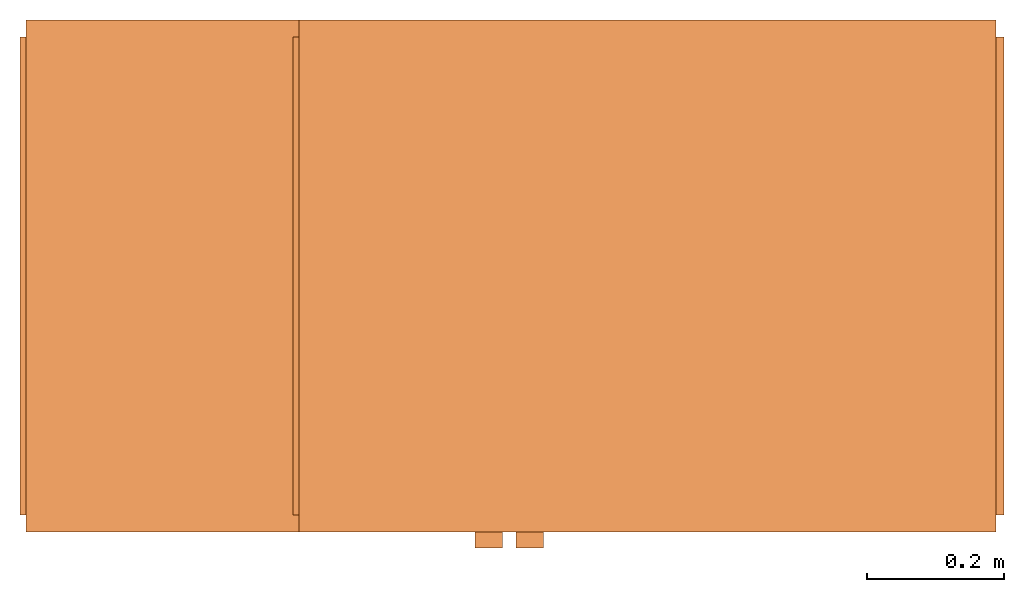
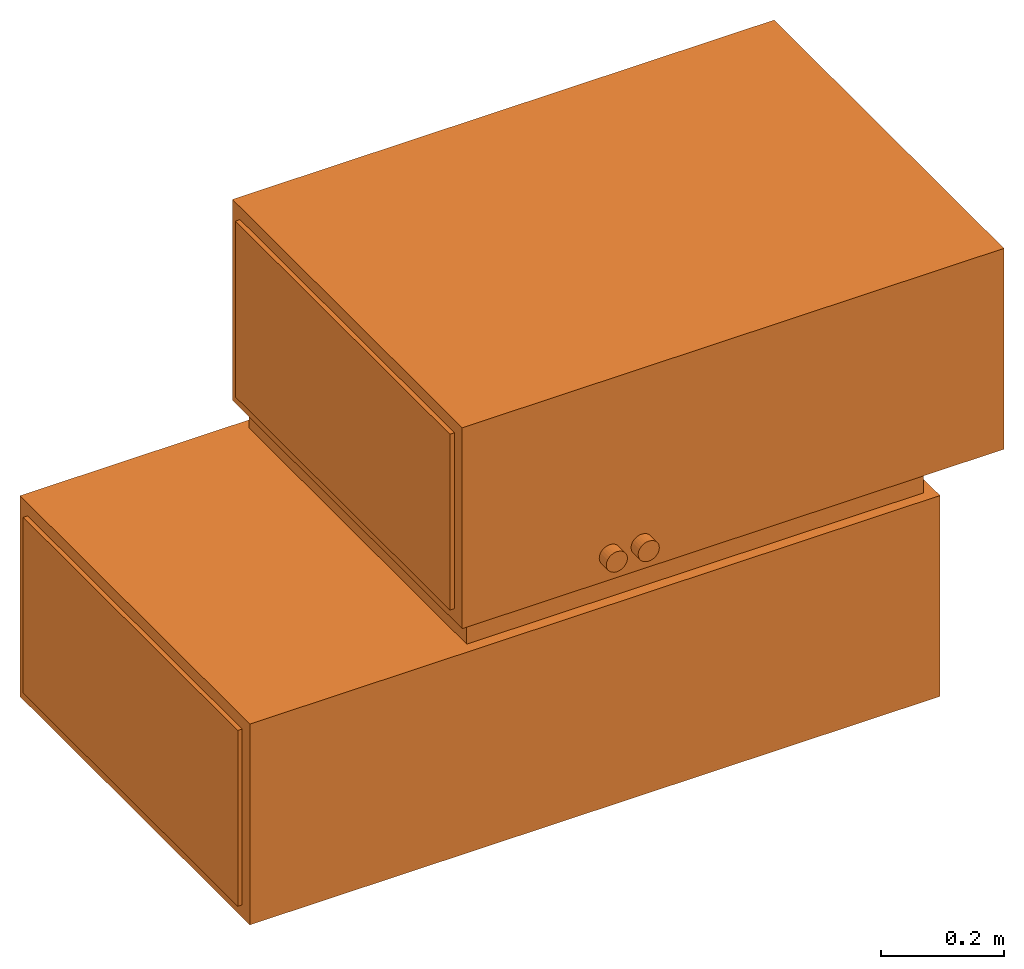
# One storey: 1 proxy.
"""IFC2X3 building model written with IfcOpenShell, lengths in millimetres."""

from ifc_helpers import new_model, entity, si_unit, converted_unit, derived_unit, direction, frame, origin, place, context, subcontext, project, spatial, faceted_brep, source, transform, mapped, type_object, type_shapes, element, save


model = new_model("IFC2X3")

# Units and contexts
model_context = context("Model", 3, precision=0.01, world=origin(), true_north=direction((6.12303176911189e-17, 1.0)))
body_context = subcontext(model_context, "Body", "Model", "MODEL_VIEW")
ifc_project = project(units=[si_unit("LENGTHUNIT", "METRE", prefix="MILLI"), si_unit("AREAUNIT", "SQUARE_METRE"), si_unit("VOLUMEUNIT", "CUBIC_METRE"), converted_unit("PLANEANGLEUNIT", "DEGREE", entity("IfcRatioMeasure", 0.0174532925199433), si_unit("PLANEANGLEUNIT", "RADIAN"), dimensions=[0, 0, 0, 0, 0, 0, 0]), si_unit("MASSUNIT", "GRAM", prefix="KILO"), derived_unit("MASSDENSITYUNIT", [(si_unit("MASSUNIT", "GRAM", prefix="KILO"), 1), (si_unit("LENGTHUNIT", "METRE"), -3)]), si_unit("TIMEUNIT", "SECOND"), si_unit("FREQUENCYUNIT", "HERTZ"), si_unit("THERMODYNAMICTEMPERATUREUNIT", "DEGREE_CELSIUS"), derived_unit("THERMALTRANSMITTANCEUNIT", [(si_unit("MASSUNIT", "GRAM", prefix="KILO"), 1), (si_unit("THERMODYNAMICTEMPERATUREUNIT", "KELVIN"), -1), (si_unit("TIMEUNIT", "SECOND"), -3)]), derived_unit("VOLUMETRICFLOWRATEUNIT", [(si_unit("LENGTHUNIT", "METRE"), 3), (si_unit("TIMEUNIT", "SECOND"), -1)]), si_unit("ELECTRICCURRENTUNIT", "AMPERE"), si_unit("ELECTRICVOLTAGEUNIT", "VOLT"), si_unit("POWERUNIT", "WATT"), si_unit("FORCEUNIT", "NEWTON", prefix="KILO"), si_unit("ILLUMINANCEUNIT", "LUX"), si_unit("LUMINOUSFLUXUNIT", "LUMEN"), si_unit("LUMINOUSINTENSITYUNIT", "CANDELA"), derived_unit("USERDEFINED", [(si_unit("MASSUNIT", "GRAM", prefix="KILO"), -1), (si_unit("LENGTHUNIT", "METRE"), -2), (si_unit("TIMEUNIT", "SECOND"), 3), (si_unit("LUMINOUSFLUXUNIT", "LUMEN"), 1)]), derived_unit("LINEARVELOCITYUNIT", [(si_unit("LENGTHUNIT", "METRE"), 1), (si_unit("TIMEUNIT", "SECOND"), -1)]), si_unit("PRESSUREUNIT", "PASCAL"), derived_unit("USERDEFINED", [(si_unit("LENGTHUNIT", "METRE"), -2), (si_unit("MASSUNIT", "GRAM", prefix="KILO"), 1), (si_unit("TIMEUNIT", "SECOND"), -2)])], contexts=[model_context])

# Site, building, storey
site_placement = place(None, origin())
site = spatial("IfcSite", under=ifc_project, at=site_placement, CompositionType="ELEMENT")
building_placement = place(site_placement, origin())
building = spatial("IfcBuilding", under=site, at=building_placement, CompositionType="ELEMENT")
storey_placement = place(building_placement, frame((0.0, 0.0, 16000.0)))
storey = spatial("IfcBuildingStorey", under=building, at=storey_placement, Name="04 Roof", CompositionType="ELEMENT", Elevation=16000.0)

# Proxy
building_element_proxy_type = type_object("IfcBuildingElementProxyType", PredefinedType="NOTDEFINED")
shared_shape = source(origin(), body_context, "Body", "Brep", [
    faceted_brep([(-163.511826637616, -398.024288, 482.679491924311), (-159.369691013885, -398.024288, 485.857864376269), (-156.191318561927, -398.024288, 490.0), (-154.193310111835, -398.024288, 494.823619097949), (-153.511826637616, -398.024288, 500.0), (-154.193310111834, -398.024288, 505.17638090205), (-156.191318561927, -398.024288, 510.0), (-159.369691013885, -398.024288, 514.142135623731), (-163.511826637616, -398.024288, 517.320508075689), (-168.335445735565, -398.024288, 519.318516525781), (-173.511826637616, -398.024288, 520.0), (-178.688207539666, -398.024288, 519.318516525781), (-183.511826637616, -398.024288, 517.320508075689), (-187.653962261347, -398.024288, 514.142135623731), (-190.832334713305, -398.024288, 510.0), (-192.830343163397, -398.024288, 505.17638090205), (-193.511826637616, -398.024288, 500.0), (-192.830343163397, -398.024288, 494.823619097949), (-190.832334713305, -398.024288, 490.0), (-187.653962261347, -398.024288, 485.857864376269), (-183.511826637616, -398.024288, 482.679491924311), (-178.688207539666, -398.024288, 480.681483474218), (-173.511826637616, -398.024288, 480.0), (-168.335445735566, -398.024288, 480.681483474218), (-113.511826637616, -398.024288, 480.0), (-108.335445735565, -398.024288, 480.681483474218), (-103.511826637616, -398.024288, 482.679491924311), (-99.3696910138849, -398.024288, 485.857864376269), (-96.1913185619271, -398.024288, 490.0), (-94.1933101118345, -398.024288, 494.823619097949), (-93.5118266376158, -398.024288, 500.0), (-94.1933101118344, -398.024288, 505.17638090205), (-96.191318561927, -398.024288, 510.0), (-99.3696910138848, -398.024288, 514.142135623731), (-103.511826637616, -398.024288, 517.320508075688), (-108.335445735565, -398.024288, 519.318516525781), (-113.511826637616, -398.024288, 520.0), (-118.688207539666, -398.024288, 519.318516525781), (-123.511826637616, -398.024288, 517.320508075688), (-127.653962261347, -398.024288, 514.142135623731), (-130.832334713305, -398.024288, 510.0), (-132.830343163397, -398.024288, 505.17638090205), (-133.511826637616, -398.024288, 500.0), (-132.830343163397, -398.024288, 494.823619097949), (-130.832334713305, -398.024288, 490.0), (-127.653962261347, -398.024288, 485.857864376269), (-123.511826637616, -398.024288, 482.679491924311), (-118.688207539666, -398.024288, 480.681483474218), (-431.478368556357, 355.0, 450.0), (428.521631443643, 355.0, 450.0), (428.521631443643, 355.0, 400.0), (-431.478368556357, 355.0, 400.0), (-431.478368556357, -355.0, 450.0), (-431.478368556357, -355.0, 400.0), (428.521631443643, -355.0, 450.0), (428.521631443643, -355.0, 400.0), (-451.478368556357, 375.0, 450.0), (-451.478368556357, -375.0, 450.0), (568.966310888472, 375.0, 450.0), (568.966310888472, -375.0, 450.0), (568.966310888472, -375.0, 850.0), (568.966310888472, 375.0, 850.0), (-451.478368556357, 375.0, 850.0), (-451.478368556357, -375.0, 850.0), (-851.478368556357, 375.0, 400.0), (448.521631443643, 375.0, 400.0), (448.521631443643, 375.0, 0.0), (-851.478368556357, 375.0, 0.0), (-451.478368556357, 350.0, 825.0), (-451.478368556357, -350.0, 825.0), (-451.478368556357, 350.0, 475.0), (-451.478368556357, -350.0, 475.0), (-183.511826637616, -375.0, 517.320508075689), (-178.688207539666, -375.0, 519.318516525781), (-187.653962261347, -375.0, 514.142135623731), (-173.511826637616, -375.0, 520.0), (-113.511826637616, -375.0, 520.0), (-108.335445735565, -375.0, 519.318516525781), (-190.832334713305, -375.0, 510.0), (-192.830343163397, -375.0, 505.17638090205), (-193.511826637616, -375.0, 500.0), (-192.830343163397, -375.0, 494.823619097949), (-190.832334713305, -375.0, 490.0), (-187.653962261347, -375.0, 485.857864376269), (-183.511826637616, -375.0, 482.679491924311), (-178.688207539666, -375.0, 480.681483474218), (-173.511826637616, -375.0, 480.0), (-113.511826637616, -375.0, 480.0), (-94.1933101118345, -375.0, 505.17638090205), (-93.5118266376158, -375.0, 500.0), (-94.1933101118345, -375.0, 494.823619097949), (-96.1913185619271, -375.0, 490.0), (-99.3696910138849, -375.0, 485.857864376269), (-108.335445735565, -375.0, 480.681483474218), (-103.511826637616, -375.0, 482.679491924311), (-168.335445735566, -375.0, 480.681483474218), (-118.688207539666, -375.0, 480.681483474218), (-163.511826637616, -375.0, 482.679491924311), (-123.511826637616, -375.0, 482.679491924311), (-159.369691013885, -375.0, 485.857864376269), (-127.653962261347, -375.0, 485.857864376269), (-156.191318561927, -375.0, 490.0), (-130.832334713305, -375.0, 490.0), (-154.193310111835, -375.0, 494.823619097949), (-132.830343163397, -375.0, 494.823619097949), (-153.511826637616, -375.0, 500.0), (-133.511826637616, -375.0, 500.0), (-154.193310111835, -375.0, 505.17638090205), (-132.830343163397, -375.0, 505.17638090205), (-156.191318561927, -375.0, 510.0), (-130.832334713305, -375.0, 510.0), (-159.369691013885, -375.0, 514.142135623731), (-127.653962261347, -375.0, 514.14213562373), (-163.511826637616, -375.0, 517.320508075689), (-123.511826637616, -375.0, 517.320508075688), (-168.335445735566, -375.0, 519.318516525781), (-118.688207539666, -375.0, 519.318516525781), (-103.511826637616, -375.0, 517.320508075688), (-99.3696910138849, -375.0, 514.142135623731), (-96.1913185619271, -375.0, 510.0), (448.521631443643, -375.0, 400.0), (-851.478368556357, -375.0, 400.0), (-851.478368556357, -375.0, 0.0), (448.521631443643, -375.0, 0.0), (568.966310888472, -350.0, 825.0), (568.966310888472, 350.0, 825.0), (568.966310888472, -350.0, 475.0), (568.966310888472, 350.0, 475.0), (-851.478368556357, 350.0, 375.0), (-851.478368556357, -350.0, 375.0), (-851.478368556357, 350.0, 25.0), (-851.478368556357, -350.0, 25.0), (448.521631443643, -350.0, 375.0), (448.521631443643, 350.0, 375.0), (448.521631443643, -350.0, 25.0), (448.521631443643, 350.0, 25.0), (-460.292668538164, 350.0, 475.0), (-460.292668538164, -350.0, 475.0), (-460.292668538164, -350.0, 825.0), (-460.292668538164, 350.0, 825.0), (-859.899821868307, -350.0, 375.0), (-859.899821868307, -350.0, 25.0), (462.971619263706, -350.0, 25.0), (462.971619263706, -350.0, 375.0), (580.898805953455, -350.0, 475.0), (580.898805953455, -350.0, 825.0), (580.898805953455, 350.0, 475.0), (-859.899821868307, 350.0, 25.0), (-859.899821868307, 350.0, 375.0), (462.971619263706, 350.0, 375.0), (462.971619263706, 350.0, 25.0), (580.898805953455, 350.0, 825.0)], [[[0, 1, 2, 3, 4, 5, 6, 7, 8, 9, 10, 11, 12, 13, 14, 15, 16, 17, 18, 19, 20, 21, 22, 23]], [[24, 25, 26, 27, 28, 29, 30, 31, 32, 33, 34, 35, 36, 37, 38, 39, 40, 41, 42, 43, 44, 45, 46, 47]], [[48, 49, 50, 51]], [[52, 48, 51, 53]], [[54, 52, 53, 55]], [[49, 54, 55, 50]], [[56, 48, 52]], [[48, 56, 49]], [[52, 57, 56]], [[58, 49, 56]], [[49, 58, 54]], [[59, 54, 58]], [[54, 59, 57]], [[57, 52, 54]], [[60, 61, 62, 63]], [[62, 61, 58, 56]], [[64, 65, 66, 67]], [[62, 68, 69]], [[68, 62, 70]], [[69, 63, 62]], [[56, 70, 62]], [[70, 56, 71]], [[57, 71, 56]], [[71, 57, 63]], [[63, 69, 71]], [[63, 72, 73]], [[72, 63, 74]], [[63, 73, 75]], [[63, 75, 76]], [[57, 74, 63]], [[77, 63, 76]], [[60, 63, 77]], [[57, 78, 74]], [[57, 79, 78]], [[80, 79, 57]], [[81, 80, 57]], [[82, 81, 57]], [[57, 83, 82]], [[83, 57, 84]], [[84, 57, 85]], [[86, 85, 57]], [[57, 87, 86]], [[59, 87, 57]], [[60, 88, 59]], [[59, 88, 89]], [[90, 59, 89]], [[90, 91, 59]], [[91, 92, 59]], [[87, 59, 93]], [[94, 93, 59]], [[59, 92, 94]], [[95, 86, 87]], [[96, 95, 87]], [[97, 95, 96]], [[96, 98, 97]], [[99, 97, 98]], [[99, 98, 100]], [[101, 99, 100]], [[102, 101, 100]], [[103, 101, 102]], [[103, 102, 104]], [[103, 104, 105]], [[106, 105, 104]], [[105, 106, 107]], [[108, 107, 106]], [[109, 107, 108]], [[108, 110, 109]], [[110, 111, 109]], [[110, 112, 111]], [[113, 111, 112]], [[114, 113, 112]], [[113, 114, 115]], [[116, 115, 114]], [[116, 75, 115]], [[76, 75, 116]], [[60, 77, 117]], [[60, 117, 118]], [[118, 119, 60]], [[119, 88, 60]], [[120, 121, 122, 123]], [[60, 124, 125]], [[124, 60, 126]], [[125, 61, 60]], [[59, 126, 60]], [[126, 59, 127]], [[58, 127, 59]], [[127, 58, 61]], [[61, 125, 127]], [[65, 50, 55]], [[50, 65, 51]], [[55, 120, 65]], [[64, 51, 65]], [[51, 64, 53]], [[121, 53, 64]], [[53, 121, 120]], [[120, 55, 53]], [[122, 67, 66, 123]], [[64, 128, 129]], [[128, 64, 130]], [[129, 121, 64]], [[67, 130, 64]], [[130, 67, 131]], [[122, 131, 67]], [[131, 122, 121]], [[121, 129, 131]], [[120, 132, 133]], [[132, 120, 134]], [[133, 65, 120]], [[123, 134, 120]], [[134, 123, 135]], [[66, 135, 123]], [[135, 66, 65]], [[65, 133, 135]], [[136, 137, 138, 139]], [[71, 69, 138, 137]], [[131, 129, 140, 141]], [[142, 143, 132, 134]], [[144, 145, 124, 126]], [[70, 71, 137, 136]], [[146, 144, 126, 127]], [[68, 70, 136, 139]], [[128, 130, 147, 148]], [[149, 150, 135, 133]], [[151, 146, 127, 125]], [[69, 68, 139, 138]], [[145, 151, 125, 124]], [[147, 141, 140, 148]], [[130, 131, 141, 147]], [[150, 142, 134, 135]], [[129, 128, 148, 140]], [[143, 149, 133, 132]], [[149, 143, 142, 150]], [[151, 145, 144, 146]], [[81, 17, 16, 80]], [[82, 18, 17, 81]], [[20, 19, 83, 84]], [[82, 83, 19, 18]], [[21, 20, 84, 85]], [[22, 21, 85, 86]], [[23, 22, 86, 95]], [[97, 0, 23, 95]], [[2, 101, 103, 3]], [[3, 103, 105, 4]], [[97, 99, 1, 0]], [[99, 101, 2, 1]], [[107, 5, 4, 105]], [[109, 6, 5, 107]], [[8, 7, 111, 113]], [[109, 111, 7, 6]], [[9, 8, 113, 115]], [[10, 9, 115, 75]], [[12, 72, 74, 13]], [[14, 78, 79, 15]], [[74, 78, 14, 13]], [[15, 79, 80, 16]], [[11, 73, 72, 12]], [[73, 11, 10, 75]], [[104, 43, 42, 106]], [[102, 44, 43, 104]], [[46, 45, 100, 98]], [[102, 100, 45, 44]], [[47, 46, 98, 96]], [[24, 47, 96, 87]], [[94, 26, 25, 93]], [[92, 27, 26, 94]], [[90, 29, 28, 91]], [[92, 91, 28, 27]], [[29, 90, 89, 30]], [[93, 25, 24, 87]], [[88, 31, 30, 89]], [[119, 32, 31, 88]], [[34, 33, 118, 117]], [[119, 118, 33, 32]], [[35, 34, 117, 77]], [[36, 35, 77, 76]], [[37, 36, 76, 116]], [[114, 38, 37, 116]], [[39, 112, 110, 40]], [[114, 112, 39, 38]], [[40, 110, 108, 41]], [[42, 41, 108, 106]]]),
])
type_shapes(building_element_proxy_type, [shared_shape])
proxy_placement = place(storey_placement, frame((29143.4900708518, -68831.2395851399, 685.950526343512)))
element("IfcBuildingElementProxy", 1, at=proxy_placement, inside=storey, type_object=building_element_proxy_type, context=body_context, shape_type="MappedRepresentation", body=[
    mapped(shared_shape, transform((0.0, 0.0, 0.0), scale=1.0)),
])

save(model, "model.ifc")
